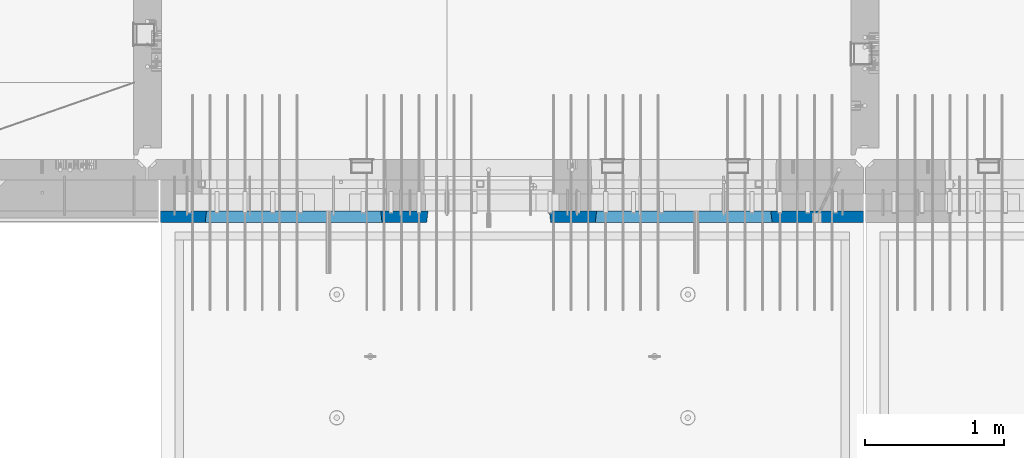
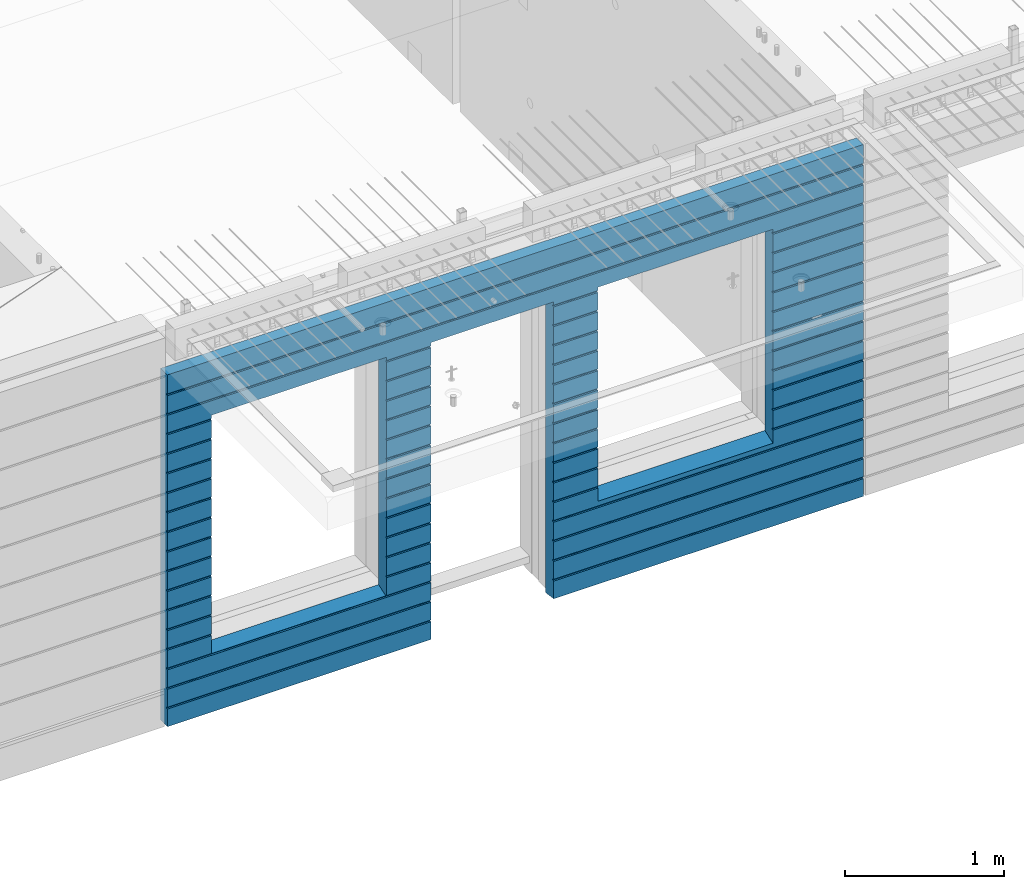
# One storey, part 231 of 350: 1 wall, 1 element without a shape of its own.
"""IFC2X3 building model written with IfcOpenShell, lengths in millimetres."""

from ifc_helpers import new_model, si_unit, frame, origin_with_axes, place, context, subcontext, project, spatial, faceted_brep, material, type_object, element, aggregate, save


model = new_model("IFC2X3")

# Units and contexts
model_context = context("Model", 3, precision=1e-05, world=origin_with_axes())
body_context = subcontext(model_context, "Body", "Model", "MODEL_VIEW")
ifc_project = project(units=[si_unit("LENGTHUNIT", "METRE", prefix="MILLI"), si_unit("AREAUNIT", "SQUARE_METRE"), si_unit("VOLUMEUNIT", "CUBIC_METRE"), si_unit("MASSUNIT", "GRAM", prefix="KILO"), si_unit("TIMEUNIT", "SECOND"), si_unit("PLANEANGLEUNIT", "RADIAN"), si_unit("SOLIDANGLEUNIT", "STERADIAN"), si_unit("THERMODYNAMICTEMPERATUREUNIT", "DEGREE_CELSIUS"), si_unit("LUMINOUSINTENSITYUNIT", "LUMEN")], contexts=[model_context])

# Site, building, storey
site_placement = place(None, origin_with_axes())
site = spatial("IfcSite", under=ifc_project, at=site_placement, CompositionType="ELEMENT")
building_placement = place(site_placement, origin_with_axes())
building = spatial("IfcBuilding", under=site, at=building_placement, CompositionType="ELEMENT")
storey_placement = place(building_placement, origin_with_axes())
storey = spatial("IfcBuildingStorey", under=building, at=storey_placement, Name="2", CompositionType="ELEMENT", Elevation=0.0)

# Assembly, wall
assembly_placement = place(storey_placement, origin_with_axes())
assembly = element("IfcElementAssembly", 1, at=assembly_placement, inside=storey, AssemblyPlace="NOTDEFINED", PredefinedType="REINFORCEMENT_UNIT")
ifc_material = material(Name="CONCRETE/C30/37")
wall_type = type_object("IfcWallType", PredefinedType="NOTDEFINED")
wall_placement = place(assembly_placement, frame((21810.0, 7587.5, 86102.5), z_axis=(0.0, 0.0, 1.0), x_axis=(-1.0, 3.00000001838171e-08, 0.0)))
wall = element("IfcWall", 2, at=wall_placement, type_object=wall_type, material=ifc_material, context=body_context, shape_type="Brep", body=[
    faceted_brep([(3465.15088791894, 41.2121213860573, -911.742424344746), (3464.99937278789, 42.5, -912.5), (3464.99937278789, 42.5, -912.000000055254), (4734.84785765683, 41.2121213860573, -911.742424344746), (4734.99937278789, 42.5, -912.5), (4734.99937278789, 42.5, -912.000000055254), (10.0, 42.5, -1347.5), (10.0, 42.5, -1212.00000005524), (2254.99845837354, 42.5, -1212.00000005524), (2254.99845837354, 42.5, -1347.5), (10.0, 32.4999992501662, -1210.00000000079), (2256.17512512844, 32.4999992501662, -1210.00000000079), (10.0000007500639, 32.499999249937, -1200.00000000079), (2256.17512514468, 32.4999991121731, -1199.99999959956), (10.0, 42.5, -1198.00000011075), (2254.99845837354, 42.5, -1198.00000011075), (10.0, 42.5, -1062.00000005522), (2254.99845837354, 42.5, -1062.00000005522), (10.0, 32.4999992506964, -1060.00000000079), (2256.17512512838, 32.4999992506964, -1060.00000000079), (10.0000007500657, 32.499999249937, -1050.00000000079), (2256.17512514461, 32.499999112697, -1049.99999959956), (10.0, 42.5, -1048.00000011074), (2254.99845837354, 42.5, -1048.00000011074), (10.0, 42.5, -912.000000055254), (2254.99845837354, 42.5, -912.000000055254), (10.0, 32.4999992512312, -910.000000000815), (2256.17512512832, 32.4999992512312, -910.000000000815), (10.0000007500657, 32.499999249937, -900.000000000786), (2256.17512514455, 32.4999991132318, -899.99999959959), (10.0, 42.5, -898.000000110769), (2254.99845837354, 42.5, -898.000000110769), (10.0, 42.5, -762.000000055225), (2254.99845837354, 42.5, -762.000000055225), (10.0, 32.4999992517696, -760.000000000771), (2256.17512512825, 32.4999992517696, -760.000000000771), (10.0000007500657, 32.499999249937, -750.000000000786), (2256.17512514449, 32.4999991137747, -749.999999599546), (10.0, 42.5, -748.00000011074), (2254.99845837354, 42.5, -748.00000011074), (675.00013572734, 42.5, 927.5), (1925.00013572734, 42.5, 927.5), (1935.00013572734, 42.5, 927.5), (1925.00013572734, -42.5, 932.5), (675.00013572734, -42.5, 932.5), (665.00013572734, 42.5, 927.5), (665.00013572734, 42.5, -712.5), (675.00013572734, -42.5, -662.5), (1925.00013572734, -42.5, -662.5), (1935.00013572734, 42.5, -712.5), (1925.00013572734, -42.5, 927.5), (1935.00013572734, 42.5, 901.999999889245), (1933.82366503463, 32.4999991119776, 900.000000400425), (1933.82366505087, 32.4999992499834, 889.9999999992), (1935.00013572734, 42.5, 887.999999944761), (1935.00013572734, 42.5, 751.999999889245), (1933.82366503463, 32.4999991119885, 750.000000400425), (1933.82366505087, 32.4999992499925, 739.9999999992), (1935.00013572734, 42.5, 737.999999944761), (1935.00013572734, 42.5, 601.99999988926), (1933.82366503463, 32.4999991120112, 600.00000040044), (1933.82366505087, 32.4999992500152, 589.999999999214), (1935.00013572734, 42.5, 587.999999944775), (1935.00013572734, 42.5, 451.999999889245), (1933.82366503464, 32.4999991120167, 450.000000400425), (1933.82366505087, 32.4999992500216, 439.9999999992), (1935.00013572734, 42.5, 437.999999944761), (1935.00013572734, 42.5, 301.999999889245), (1933.82366503464, 32.4999991120312, 300.000000400425), (1933.82366505087, 32.4999992500352, 289.9999999992), (1935.00013572734, 42.5, 287.999999944761), (1935.00013572734, 42.5, 151.999999889245), (1933.82366503464, 32.4999991120421, 150.000000400425), (1933.82366505088, 32.499999250047, 139.9999999992), (1935.00013572734, 42.5, 137.999999944761), (1935.00013572734, 42.5, 1.99999988923082), (1933.82366503515, 32.4999991164286, 4.00410499423742e-07), (1933.82366505139, 32.4999992544263, -10.0000000008149), (1935.00013572734, 42.5, -12.0000000552536), (1935.00013572734, 42.5, -148.000000110755), (1933.82366503509, 32.4999991158993, -149.99999959956), (1933.82366505132, 32.4999992538915, -160.000000000786), (1935.00013572734, 42.5, -162.000000055239), (1935.00013572734, 42.5, -298.000000110755), (1933.82366503503, 32.49999911536, -299.999999599575), (1933.82366505126, 32.4999992533594, -310.0000000008), (1935.00013572734, 42.5, -312.000000055239), (1935.00013572734, 42.5, -448.00000011074), (1933.82366503496, 32.4999991148343, -449.99999959956), (1933.8236650512, 32.4999992528337, -460.000000000786), (1935.00013572734, 42.5, -462.000000055225), (1935.00013572734, 42.5, -598.000000110755), (1933.8236650349, 32.499999114295, -599.999999599575), (1933.82366505114, 32.4999992522935, -610.0000000008), (1935.00013572734, 42.5, -612.000000055239), (2256.1751251447, 32.4999991119776, 900.000000400425), (2256.17512512846, 32.4999992499834, 889.9999999992), (2254.99845837354, 42.5, 887.999999944761), (2254.99845837354, 42.5, 751.999999889245), (2256.17512514469, 32.4999991119885, 750.000000400425), (2256.17512512846, 32.4999992499925, 739.9999999992), (2254.99845837354, 42.5, 737.999999944761), (2254.99845837354, 42.5, 601.99999988926), (2256.17512514469, 32.4999991120112, 600.00000040044), (2256.17512512846, 32.4999992500152, 589.999999999214), (2254.99845837354, 42.5, 587.999999944775), (2254.99845837354, 42.5, 451.999999889245), (2256.17512514469, 32.4999991120167, 450.000000400425), (2256.17512512846, 32.4999992500216, 439.9999999992), (2254.99845837354, 42.5, 437.999999944761), (2254.99845837354, 42.5, 301.999999889245), (2256.17512514469, 32.4999991120312, 300.000000400425), (2256.17512512846, 32.4999992500352, 289.9999999992), (2254.99845837354, 42.5, 287.999999944761), (2254.99845837354, 42.5, 151.999999889245), (2256.17512514469, 32.4999991120421, 150.000000400425), (2256.17512512846, 32.499999250047, 139.9999999992), (2254.99845837354, 42.5, 137.999999944761), (2254.99845837354, 42.5, 1.99999988923082), (2256.17512514417, 32.4999991164286, 4.00410499423742e-07), (2256.17512512794, 32.4999992544263, -10.0000000008149), (2254.99845837354, 42.5, -12.0000000552536), (2254.99845837354, 42.5, -148.000000110755), (2256.17512514424, 32.4999991158993, -149.99999959956), (2256.175125128, 32.4999992538915, -160.000000000786), (2254.99845837354, 42.5, -162.000000055239), (2254.99845837354, 42.5, -298.000000110755), (2256.1751251443, 32.49999911536, -299.999999599575), (2256.17512512806, 32.4999992533594, -310.0000000008), (2254.99845837354, 42.5, -312.000000055239), (2254.99845837354, 42.5, -448.00000011074), (2256.17512514436, 32.4999991148343, -449.99999959956), (2256.17512512813, 32.4999992528337, -460.000000000786), (2254.99845837354, 42.5, -462.000000055225), (2254.99845837354, 42.5, -598.000000110755), (2256.17512514443, 32.499999114295, -599.999999599575), (2256.17512512819, 32.4999992522935, -610.0000000008), (2254.99845837354, 42.5, -612.000000055239), (10.0, 42.5, -612.000000055239), (665.00013572734, 42.5, -612.000000055239), (10.0, 32.4999992522935, -610.0000000008), (666.176606403544, 32.4999992522935, -610.0000000008), (10.0000007500657, 32.499999249937, -600.000000000786), (666.176606419776, 32.499999114295, -599.999999599575), (10.0, 42.5, -598.000000110755), (665.00013572734, 42.5, -598.000000110755), (10.0, 42.5, -462.000000055225), (665.00013572734, 42.5, -462.000000055225), (10.0, 32.4999992528337, -460.000000000786), (666.176606403482, 32.4999992528337, -460.000000000786), (10.0000007500657, 32.499999249937, -450.000000000786), (666.176606419715, 32.4999991148343, -449.99999959956), (10.0, 42.5, -448.00000011074), (665.00013572734, 42.5, -448.00000011074), (10.0, 42.5, -312.000000055239), (665.00013572734, 42.5, -312.000000055239), (10.0, 32.4999992533594, -310.0000000008), (666.17660640342, 32.4999992533594, -310.0000000008), (10.0000007500657, 32.499999249937, -300.000000000786), (666.176606419653, 32.49999911536, -299.999999599575), (10.0, 42.5, -298.000000110755), (665.00013572734, 42.5, -298.000000110755), (10.0, 42.5, -162.000000055239), (665.00013572734, 42.5, -162.000000055239), (10.0, 32.4999992538915, -160.000000000786), (666.176606403355, 32.4999992538915, -160.000000000786), (10.0000007500657, 32.499999249937, -150.000000000786), (666.176606419591, 32.4999991158993, -149.99999959956), (10.0, 42.5, -148.000000110755), (665.00013572734, 42.5, -148.000000110755), (10.0, 42.5, -12.0000000552536), (665.00013572734, 42.5, -12.0000000552536), (10.0, 32.4999992544263, -10.0000000008149), (666.176606403293, 32.4999992544263, -10.0000000008149), (10.0000007500657, 32.499999249937, -7.8580342233181e-10), (666.176606419529, 32.4999991164286, 4.00410499423742e-07), (10.0, 42.5, 1.99999988923082), (665.00013572734, 42.5, 1.99999988923082), (10.0, 42.5, 137.999999944761), (665.00013572734, 42.5, 137.999999944761), (10.0, 32.499999250047, 139.9999999992), (666.176606403806, 32.499999250047, 139.9999999992), (10.0000007500657, 32.499999249937, 149.999999999214), (666.176606420046, 32.4999991120421, 150.000000400425), (10.0, 42.5, 151.999999889245), (665.00013572734, 42.5, 151.999999889245), (10.0, 42.5, 287.999999944761), (665.00013572734, 42.5, 287.999999944761), (10.0, 32.4999992500352, 289.9999999992), (666.176606403809, 32.4999992500352, 289.9999999992), (10.0000007500657, 32.499999249937, 299.999999999214), (666.176606420046, 32.4999991120312, 300.000000400425), (10.0, 42.5, 301.999999889245), (665.00013572734, 42.5, 301.999999889245), (10.0, 42.5, 437.999999944761), (665.00013572734, 42.5, 437.999999944761), (10.0, 32.4999992500216, 439.9999999992), (666.176606403809, 32.4999992500216, 439.9999999992), (10.0000007500657, 32.499999249937, 449.999999999214), (666.176606420046, 32.4999991120167, 450.000000400425), (10.0, 42.5, 451.999999889245), (665.00013572734, 42.5, 451.999999889245), (10.0, 42.5, 587.999999944775), (665.00013572734, 42.5, 587.999999944775), (10.0, 32.4999992500152, 589.999999999214), (666.176606403809, 32.4999992500152, 589.999999999214), (10.0000007500657, 32.499999249937, 599.999999999214), (666.176606420049, 32.4999991120112, 600.00000040044), (10.0, 42.5, 601.99999988926), (665.00013572734, 42.5, 601.99999988926), (10.0, 42.5, 737.999999944761), (665.00013572734, 42.5, 737.999999944761), (9.99999999999636, 32.4999992499925, 739.9999999992), (666.176606403813, 32.4999992499925, 739.9999999992), (10.0000007500657, 32.499999249937, 749.999999999214), (666.176606420049, 32.4999991119885, 750.000000400425), (10.0, 42.5, 751.999999889245), (665.00013572734, 42.5, 751.999999889245), (10.0, 42.5, 887.999999944761), (665.00013572734, 42.5, 887.999999944761), (10.0, 32.4999992499834, 889.9999999992), (666.176606403813, 32.4999992499834, 889.9999999992), (10.0000007500657, 32.499999249937, 899.999999999214), (666.176606420053, 32.4999991119776, 900.000000400425), (675.00013572734, -42.5, 927.5), (665.00013572734, 42.5, 901.999999889245), (10.0, 42.5, 901.999999889245), (10.0, 42.5, 1051.99999988925), (5055.0, 42.5, 1051.99999988925), (5055.0, 32.4999991119666, 1050.00000040043), (10.0000007500657, 32.499999249937, 1049.99999999921), (5055.0, 32.4999992499706, 1039.9999999992), (10.0, 32.4999992499706, 1039.9999999992), (5055.0, 42.5, 1037.99999994476), (10.0, 42.5, 1037.99999994476), (5055.0, 42.5, 901.999999889245), (5055.0, 32.4999991119776, 900.000000400425), (4733.82290209518, 32.4999991119776, 900.000000400425), (4734.99937278789, 42.5, 901.999999889245), (5055.0, 32.4999992499834, 889.9999999992), (4733.82290211141, 32.4999992499834, 889.9999999992), (5055.0, 42.5, 887.999999944761), (4734.99937278789, 42.5, 887.999999944761), (5055.0, 42.5, 751.999999889245), (4734.99937278789, 42.5, 751.999999889245), (5055.0, 32.4999991119885, 750.000000400425), (4733.82290209518, 32.4999991119885, 750.000000400425), (5055.0, 32.4999992499925, 739.9999999992), (4733.82290211142, 32.4999992499925, 739.9999999992), (5055.0, 42.5, 737.999999944761), (4734.99937278789, 42.5, 737.999999944761), (5055.0, 42.5, 601.99999988926), (4734.99937278789, 42.5, 601.99999988926), (5055.0, 32.4999991120112, 600.00000040044), (4733.82290209518, 32.4999991120112, 600.00000040044), (5055.0, 32.4999992500152, 589.999999999214), (4733.82290211142, 32.4999992500152, 589.999999999214), (5055.0, 42.5, 587.999999944775), (4734.99937278789, 42.5, 587.999999944775), (5055.0, 42.5, 451.999999889245), (4734.99937278789, 42.5, 451.999999889245), (5055.0, 32.4999991120167, 450.000000400425), (4733.82290209518, 32.4999991120167, 450.000000400425), (5055.0, 32.4999992500216, 439.9999999992), (4733.82290211142, 32.4999992500216, 439.9999999992), (5055.0, 42.5, 437.999999944761), (4734.99937278789, 42.5, 437.999999944761), (5055.0, 42.5, 301.999999889245), (4734.99937278789, 42.5, 301.999999889245), (5055.0, 32.4999991120312, 300.000000400425), (4733.82290209518, 32.4999991120312, 300.000000400425), (5055.0, 32.4999992500352, 289.9999999992), (4733.82290211142, 32.4999992500352, 289.9999999992), (5055.0, 42.5, 287.999999944761), (4734.99937278789, 42.5, 287.999999944761), (5055.0, 42.5, 151.999999889245), (4734.99937278789, 42.5, 151.999999889245), (5055.0, 32.4999991120421, 150.000000400425), (4733.82290209519, 32.4999991120421, 150.000000400425), (5055.0, 32.499999250047, 139.9999999992), (4733.82290211142, 32.499999250047, 139.9999999992), (5055.0, 42.5, 137.999999944761), (4734.99937278789, 42.5, 137.999999944761), (5055.0, 42.5, 1.99999988923082), (4734.99937278789, 42.5, 1.99999988923082), (5055.0, 32.4999991164286, 4.00410499423742e-07), (4733.8229020957, 32.4999991164286, 4.00410499423742e-07), (5055.0, 32.4999992544263, -10.0000000008149), (4733.82290211194, 32.4999992544263, -10.0000000008149), (5055.0, 42.5, -12.0000000552536), (4734.99937278789, 42.5, -12.0000000552536), (5055.0, 42.5, -148.000000110755), (4734.99937278789, 42.5, -148.000000110755), (5055.0, 32.4999991158993, -149.99999959956), (4733.82290209564, 32.4999991158993, -149.99999959956), (5055.0, 32.4999992538915, -160.000000000786), (4733.82290211188, 32.4999992538915, -160.000000000786), (5055.0, 42.5, -162.000000055239), (4734.99937278789, 42.5, -162.000000055239), (5055.0, 42.5, -298.000000110755), (4734.99937278789, 42.5, -298.000000110755), (5055.0, 32.49999911536, -299.999999599575), (4733.82290209558, 32.49999911536, -299.999999599575), (5055.0, 32.4999992533594, -310.0000000008), (4733.82290211181, 32.4999992533594, -310.0000000008), (5055.0, 42.5, -312.000000055239), (4734.99937278789, 42.5, -312.000000055239), (5055.0, 42.5, -448.00000011074), (4734.99937278789, 42.5, -448.00000011074), (5055.0, 32.4999991148343, -449.99999959956), (4733.82290209552, 32.4999991148343, -449.99999959956), (5055.0, 32.4999992528337, -460.000000000786), (4733.82290211175, 32.4999992528337, -460.000000000786), (5055.0, 42.5, -462.000000055225), (4734.99937278789, 42.5, -462.000000055225), (5055.0, 42.5, -598.000000110755), (4734.99937278789, 42.5, -598.000000110755), (5055.0, 32.499999114295, -599.999999599575), (4733.82290209545, 32.499999114295, -599.999999599575), (5055.0, 32.4999992522935, -610.0000000008), (4733.82290211169, 32.4999992522935, -610.0000000008), (5055.0, 42.5, -612.000000055239), (4734.99937278789, 42.5, -612.000000055239), (5055.0, 42.5, -748.00000011074), (4734.99937278789, 42.5, -748.00000011074), (5055.0, 32.4999991137747, -749.999999599546), (4733.82290209539, 32.4999991137747, -749.999999599546), (5055.0, 32.4999992517696, -760.000000000771), (4733.82290211162, 32.4999992517696, -760.000000000771), (5055.0, 42.5, -762.000000055225), (4734.99937278789, 42.5, -762.000000055225), (5055.0, 42.5, -898.000000110769), (4734.99937278789, 42.5, -898.000000110769), (5055.0, 32.4999991132318, -899.99999959959), (4733.82290209533, 32.4999991132318, -899.99999959959), (3466.1758434697, 32.499999204555, -906.617646590923), (3474.99937278789, -42.5, -862.5), (4724.99937278789, -42.5, -862.5), (4733.82290210607, 32.499999204555, -906.617646590923), (4724.99937278789, -42.5, 927.5), (4724.99937278789, -42.5, 932.5), (4734.99937278789, 42.5, 927.5), (2265.00051719707, 42.5, 927.5), (3135.00051719707, 42.5, 927.5), (3144.99845837354, 42.5, 927.5), (3134.99679170688, -42.5, 932.502857142856), (2265.00012504021, -42.5, 932.502857142856), (2254.99845837354, 42.5, 927.5), (4724.99937278789, 42.5, 927.5), (3474.99937278789, 42.5, 927.5), (3464.99937278789, 42.5, 927.5), (3464.99937278789, 42.5, 901.999999889245), (3144.99845837354, 42.5, 901.999999889245), (2254.99845837354, 42.5, 901.999999889245), (2265.00012504021, -42.5, 927.5), (2265.00012504021, -42.5, -1347.5), (10.0, -42.5, -1347.5), (10.0, 42.5, 1347.5), (10.0, -42.5, 1347.5), (5055.0, -42.5, 1347.5), (5055.0, 42.5, 1347.5), (5055.0, 42.5, 1201.99999988925), (10.0, 42.5, 1201.99999988925), (10.0, 42.5, 1187.99999994476), (10.0000007500657, 32.499999249937, 1199.99999999921), (9.99999999999636, 32.4999992499606, 1189.9999999992), (5055.0, 42.5, 1187.99999994476), (5055.0, 32.4999992499606, 1189.9999999992), (5055.0, 32.4999991119566, 1200.00000040043), (5055.0, -42.5, -1347.5), (5055.0, 42.5, -1347.5), (5055.0, 42.5, -1212.00000005524), (5055.0, 32.4999992501662, -1210.00000000079), (5055.0, 32.4999991121731, -1199.99999959956), (5055.0, 42.5, -1198.00000011075), (5055.0, 42.5, -1062.00000005522), (5055.0, 32.4999992506964, -1060.00000000079), (5055.0, 32.499999112697, -1049.99999959956), (5055.0, 42.5, -1048.00000011074), (5055.0, 42.5, -912.000000055254), (5055.0, 32.4999992512312, -910.000000000815), (3144.99845837354, 42.5, -1212.00000005524), (3143.82179161865, 32.4999992501662, -1210.00000000079), (3143.82179160241, 32.4999991121731, -1199.99999959956), (3144.99845837354, 42.5, -1198.00000011075), (3144.99845837354, 42.5, -1062.00000005522), (3143.82179161871, 32.4999992506964, -1060.00000000079), (3143.82179160247, 32.499999112697, -1049.99999959956), (3144.99845837354, 42.5, -1048.00000011074), (3144.99845837354, 42.5, -912.000000055254), (3143.82179161877, 32.4999992512312, -910.000000000815), (3466.17584348045, 32.4999991132318, -899.99999959959), (3143.82179160253, 32.4999991132318, -899.99999959959), (3464.99937278789, 42.5, -898.000000110769), (3144.99845837354, 42.5, -898.000000110769), (3464.99937278789, 42.5, -762.000000055225), (3144.99845837354, 42.5, -762.000000055225), (3466.17584346415, 32.4999992517696, -760.000000000771), (3143.82179161884, 32.4999992517696, -760.000000000771), (3466.17584348039, 32.4999991137747, -749.999999599546), (3143.8217916026, 32.4999991137747, -749.999999599546), (3464.99937278789, 42.5, -748.00000011074), (3144.99845837354, 42.5, -748.00000011074), (3464.99937278789, 42.5, -612.000000055239), (3144.99845837354, 42.5, -612.000000055239), (3466.17584346409, 32.4999992522935, -610.0000000008), (3143.8217916189, 32.4999992522935, -610.0000000008), (3466.17584348032, 32.499999114295, -599.999999599575), (3143.82179160266, 32.499999114295, -599.999999599575), (3464.99937278789, 42.5, -598.000000110755), (3144.99845837354, 42.5, -598.000000110755), (3464.99937278789, 42.5, -462.000000055225), (3144.99845837354, 42.5, -462.000000055225), (3466.17584346403, 32.4999992528337, -460.000000000786), (3143.82179161896, 32.4999992528337, -460.000000000786), (3466.17584348026, 32.4999991148343, -449.99999959956), (3143.82179160272, 32.4999991148343, -449.99999959956), (3464.99937278789, 42.5, -448.00000011074), (3144.99845837354, 42.5, -448.00000011074), (3464.99937278789, 42.5, -312.000000055239), (3144.99845837354, 42.5, -312.000000055239), (3466.17584346396, 32.4999992533594, -310.0000000008), (3143.82179161902, 32.4999992533594, -310.0000000008), (3466.1758434802, 32.49999911536, -299.999999599575), (3143.82179160278, 32.49999911536, -299.999999599575), (3464.99937278789, 42.5, -298.000000110755), (3144.99845837354, 42.5, -298.000000110755), (3464.99937278789, 42.5, -162.000000055239), (3144.99845837354, 42.5, -162.000000055239), (3466.1758434639, 32.4999992538915, -160.000000000786), (3143.82179161909, 32.4999992538915, -160.000000000786), (3466.17584348014, 32.4999991158993, -149.99999959956), (3143.82179160284, 32.4999991158993, -149.99999959956), (3464.99937278789, 42.5, -148.000000110755), (3144.99845837354, 42.5, -148.000000110755), (3464.99937278789, 42.5, -12.0000000552536), (3144.99845837354, 42.5, -12.0000000552536), (3466.17584346384, 32.4999992544263, -10.0000000008149), (3143.82179161915, 32.4999992544263, -10.0000000008149), (3466.17584348008, 32.4999991164286, 4.00410499423742e-07), (3143.82179160291, 32.4999991164286, 4.00410499423742e-07), (3464.99937278789, 42.5, 1.99999988923082), (3144.99845837354, 42.5, 1.99999988923082), (3464.99937278789, 42.5, 137.999999944761), (3144.99845837354, 42.5, 137.999999944761), (3466.17584346435, 32.499999250047, 139.9999999992), (3143.82179161863, 32.499999250047, 139.9999999992), (3466.17584348059, 32.4999991120421, 150.000000400425), (3143.82179160239, 32.4999991120421, 150.000000400425), (3464.99937278789, 42.5, 151.999999889245), (3144.99845837354, 42.5, 151.999999889245), (3464.99937278789, 42.5, 287.999999944761), (3144.99845837354, 42.5, 287.999999944761), (3466.17584346436, 32.4999992500352, 289.9999999992), (3143.82179161863, 32.4999992500352, 289.9999999992), (3466.17584348059, 32.4999991120312, 300.000000400425), (3143.82179160239, 32.4999991120312, 300.000000400425), (3464.99937278789, 42.5, 301.999999889245), (3144.99845837354, 42.5, 301.999999889245), (3464.99937278789, 42.5, 437.999999944761), (3144.99845837354, 42.5, 437.999999944761), (3466.17584346436, 32.4999992500216, 439.9999999992), (3143.82179161863, 32.4999992500216, 439.9999999992), (3466.17584348059, 32.4999991120167, 450.000000400425), (3143.82179160239, 32.4999991120167, 450.000000400425), (3464.99937278789, 42.5, 451.999999889245), (3144.99845837354, 42.5, 451.999999889245), (3464.99937278789, 42.5, 587.999999944775), (3144.99845837354, 42.5, 587.999999944775), (3466.17584346436, 32.4999992500152, 589.999999999214), (3143.82179161863, 32.4999992500152, 589.999999999214), (3466.1758434806, 32.4999991120112, 600.00000040044), (3143.82179160239, 32.4999991120112, 600.00000040044), (3464.99937278789, 42.5, 601.99999988926), (3144.99845837354, 42.5, 601.99999988926), (3464.99937278789, 42.5, 737.999999944761), (3144.99845837354, 42.5, 737.999999944761), (3466.17584346436, 32.4999992499925, 739.9999999992), (3143.82179161863, 32.4999992499925, 739.9999999992), (3466.1758434806, 32.4999991119885, 750.000000400425), (3143.82179160239, 32.4999991119885, 750.000000400425), (3464.99937278789, 42.5, 751.999999889245), (3144.99845837354, 42.5, 751.999999889245), (3464.99937278789, 42.5, 887.999999944761), (3144.99845837354, 42.5, 887.999999944761), (3466.17584346436, 32.4999992499834, 889.9999999992), (3143.82179161863, 32.4999992499834, 889.9999999992), (3466.1758434806, 32.4999991119776, 900.000000400425), (3143.82179160239, 32.4999991119776, 900.000000400425), (3474.99937278789, -42.5, 932.5), (3474.99937278789, -42.5, 927.5), (3134.99679170688, -42.5, 927.5), (3134.99679170688, -42.5, -1347.5), (3144.99845837354, 42.5, -1347.5)], [[[0, 1, 2]], [[3, 4, 1, 0]], [[5, 4, 3]], [[6, 7, 8, 9]], [[7, 10, 11, 8]], [[10, 12, 13, 11]], [[12, 14, 15, 13]], [[14, 16, 17, 15]], [[16, 18, 19, 17]], [[18, 20, 21, 19]], [[20, 22, 23, 21]], [[22, 24, 25, 23]], [[24, 26, 27, 25]], [[26, 28, 29, 27]], [[28, 30, 31, 29]], [[30, 32, 33, 31]], [[32, 34, 35, 33]], [[34, 36, 37, 35]], [[36, 38, 39, 37]], [[40, 41, 42, 43, 44, 45]], [[46, 47, 48, 49]], [[50, 43, 42, 51, 52, 53, 54, 55, 56, 57, 58, 59, 60, 61, 62, 63, 64, 65, 66, 67, 68, 69, 70, 71, 72, 73, 74, 75, 76, 77, 78, 79, 80, 81, 82, 83, 84, 85, 86, 87, 88, 89, 90, 91, 92, 93, 94, 49, 48]], [[53, 52, 95, 96]], [[54, 53, 96, 97]], [[55, 54, 97, 98]], [[56, 55, 98, 99]], [[57, 56, 99, 100]], [[58, 57, 100, 101]], [[59, 58, 101, 102]], [[60, 59, 102, 103]], [[61, 60, 103, 104]], [[62, 61, 104, 105]], [[63, 62, 105, 106]], [[64, 63, 106, 107]], [[65, 64, 107, 108]], [[66, 65, 108, 109]], [[67, 66, 109, 110]], [[68, 67, 110, 111]], [[69, 68, 111, 112]], [[70, 69, 112, 113]], [[71, 70, 113, 114]], [[72, 71, 114, 115]], [[73, 72, 115, 116]], [[74, 73, 116, 117]], [[75, 74, 117, 118]], [[76, 75, 118, 119]], [[77, 76, 119, 120]], [[78, 77, 120, 121]], [[79, 78, 121, 122]], [[80, 79, 122, 123]], [[81, 80, 123, 124]], [[82, 81, 124, 125]], [[83, 82, 125, 126]], [[84, 83, 126, 127]], [[85, 84, 127, 128]], [[86, 85, 128, 129]], [[87, 86, 129, 130]], [[88, 87, 130, 131]], [[89, 88, 131, 132]], [[90, 89, 132, 133]], [[91, 90, 133, 134]], [[92, 91, 134, 135]], [[93, 92, 135, 136]], [[94, 93, 136, 137]], [[38, 138, 139, 46, 49, 94, 137, 39]], [[138, 140, 141, 139]], [[140, 142, 143, 141]], [[142, 144, 145, 143]], [[144, 146, 147, 145]], [[146, 148, 149, 147]], [[148, 150, 151, 149]], [[150, 152, 153, 151]], [[152, 154, 155, 153]], [[154, 156, 157, 155]], [[156, 158, 159, 157]], [[158, 160, 161, 159]], [[160, 162, 163, 161]], [[162, 164, 165, 163]], [[164, 166, 167, 165]], [[166, 168, 169, 167]], [[168, 170, 171, 169]], [[170, 172, 173, 171]], [[172, 174, 175, 173]], [[174, 176, 177, 175]], [[176, 178, 179, 177]], [[178, 180, 181, 179]], [[180, 182, 183, 181]], [[182, 184, 185, 183]], [[184, 186, 187, 185]], [[186, 188, 189, 187]], [[188, 190, 191, 189]], [[190, 192, 193, 191]], [[192, 194, 195, 193]], [[194, 196, 197, 195]], [[196, 198, 199, 197]], [[198, 200, 201, 199]], [[200, 202, 203, 201]], [[202, 204, 205, 203]], [[204, 206, 207, 205]], [[206, 208, 209, 207]], [[208, 210, 211, 209]], [[210, 212, 213, 211]], [[212, 214, 215, 213]], [[214, 216, 217, 215]], [[216, 218, 219, 217]], [[218, 220, 221, 219]], [[220, 222, 223, 221]], [[45, 44, 224, 47, 46, 139, 141, 143, 145, 147, 149, 151, 153, 155, 157, 159, 161, 163, 165, 167, 169, 171, 173, 175, 177, 179, 181, 183, 185, 187, 189, 191, 193, 195, 197, 199, 201, 203, 205, 207, 209, 211, 213, 215, 217, 219, 221, 223, 225]], [[222, 226, 225, 223]], [[227, 228, 229, 230]], [[230, 229, 231, 232]], [[232, 231, 233, 234]], [[235, 236, 237, 238]], [[236, 239, 240, 237]], [[239, 241, 242, 240]], [[241, 243, 244, 242]], [[243, 245, 246, 244]], [[245, 247, 248, 246]], [[247, 249, 250, 248]], [[249, 251, 252, 250]], [[251, 253, 254, 252]], [[253, 255, 256, 254]], [[255, 257, 258, 256]], [[257, 259, 260, 258]], [[259, 261, 262, 260]], [[261, 263, 264, 262]], [[263, 265, 266, 264]], [[265, 267, 268, 266]], [[267, 269, 270, 268]], [[269, 271, 272, 270]], [[271, 273, 274, 272]], [[273, 275, 276, 274]], [[275, 277, 278, 276]], [[277, 279, 280, 278]], [[279, 281, 282, 280]], [[281, 283, 284, 282]], [[283, 285, 286, 284]], [[285, 287, 288, 286]], [[287, 289, 290, 288]], [[289, 291, 292, 290]], [[291, 293, 294, 292]], [[293, 295, 296, 294]], [[295, 297, 298, 296]], [[297, 299, 300, 298]], [[299, 301, 302, 300]], [[301, 303, 304, 302]], [[303, 305, 306, 304]], [[305, 307, 308, 306]], [[307, 309, 310, 308]], [[309, 311, 312, 310]], [[311, 313, 314, 312]], [[313, 315, 316, 314]], [[315, 317, 318, 316]], [[317, 319, 320, 318]], [[319, 321, 322, 320]], [[321, 323, 324, 322]], [[323, 325, 326, 324]], [[325, 327, 328, 326]], [[327, 329, 330, 328]], [[329, 331, 332, 330]], [[331, 333, 334, 332]], [[335, 336, 337, 338]], [[339, 340, 341, 238, 237, 240, 242, 244, 246, 248, 250, 252, 254, 256, 258, 260, 262, 264, 266, 268, 270, 272, 274, 276, 278, 280, 282, 284, 286, 288, 290, 292, 294, 296, 298, 300, 302, 304, 306, 308, 310, 312, 314, 316, 318, 320, 322, 324, 326, 328, 330, 332, 334, 338, 337]], [[342, 343, 344, 345, 346, 347]], [[51, 42, 41, 40, 45, 225, 226, 234, 233, 235, 238, 341, 348, 349, 350, 351, 352, 344, 343, 342, 347, 353]], [[52, 51, 353, 95]], [[347, 346, 354, 355, 9, 8, 11, 13, 15, 17, 19, 21, 23, 25, 27, 29, 31, 33, 35, 37, 39, 137, 136, 135, 134, 133, 132, 131, 130, 129, 128, 127, 126, 125, 124, 123, 122, 121, 120, 119, 118, 117, 116, 115, 114, 113, 112, 111, 110, 109, 108, 107, 106, 105, 104, 103, 102, 101, 100, 99, 98, 97, 96, 95, 353]], [[356, 6, 9, 355]], [[357, 358, 359, 360]], [[357, 360, 361, 362]], [[363, 227, 230, 232, 234, 226, 222, 220, 218, 216, 214, 212, 210, 208, 206, 204, 202, 200, 198, 196, 194, 192, 190, 188, 186, 184, 182, 180, 178, 176, 174, 172, 170, 168, 166, 164, 162, 160, 158, 156, 154, 152, 150, 148, 146, 144, 142, 140, 138, 38, 36, 34, 32, 30, 28, 26, 24, 22, 20, 18, 16, 14, 12, 10, 7, 6, 356, 358, 357, 362, 364, 365]], [[228, 227, 363, 366]], [[365, 367, 366, 363]], [[364, 368, 367, 365]], [[362, 361, 368, 364]], [[360, 359, 369, 370, 371, 372, 373, 374, 375, 376, 377, 378, 379, 380, 333, 331, 329, 327, 325, 323, 321, 319, 317, 315, 313, 311, 309, 307, 305, 303, 301, 299, 297, 295, 293, 291, 289, 287, 285, 283, 281, 279, 277, 275, 273, 271, 269, 267, 265, 263, 261, 259, 257, 255, 253, 251, 249, 247, 245, 243, 241, 239, 236, 235, 233, 231, 229, 228, 366, 367, 368, 361]], [[372, 371, 381, 382]], [[373, 372, 382, 383]], [[374, 373, 383, 384]], [[375, 374, 384, 385]], [[376, 375, 385, 386]], [[377, 376, 386, 387]], [[378, 377, 387, 388]], [[2, 1, 4, 5, 379, 378, 388, 389]], [[380, 379, 5, 3, 0, 2, 389, 390]], [[391, 335, 338, 334, 333, 380, 390, 392]], [[393, 391, 392, 394]], [[395, 393, 394, 396]], [[397, 395, 396, 398]], [[399, 397, 398, 400]], [[401, 399, 400, 402]], [[403, 401, 402, 404]], [[405, 403, 404, 406]], [[407, 405, 406, 408]], [[409, 407, 408, 410]], [[411, 409, 410, 412]], [[413, 411, 412, 414]], [[415, 413, 414, 416]], [[417, 415, 416, 418]], [[419, 417, 418, 420]], [[421, 419, 420, 422]], [[423, 421, 422, 424]], [[425, 423, 424, 426]], [[427, 425, 426, 428]], [[429, 427, 428, 430]], [[431, 429, 430, 432]], [[433, 431, 432, 434]], [[435, 433, 434, 436]], [[437, 435, 436, 438]], [[439, 437, 438, 440]], [[441, 439, 440, 442]], [[443, 441, 442, 444]], [[445, 443, 444, 446]], [[447, 445, 446, 448]], [[449, 447, 448, 450]], [[451, 449, 450, 452]], [[453, 451, 452, 454]], [[455, 453, 454, 456]], [[457, 455, 456, 458]], [[459, 457, 458, 460]], [[461, 459, 460, 462]], [[463, 461, 462, 464]], [[465, 463, 464, 466]], [[467, 465, 466, 468]], [[469, 467, 468, 470]], [[471, 469, 470, 472]], [[473, 471, 472, 474]], [[475, 473, 474, 476]], [[477, 475, 476, 478]], [[479, 477, 478, 480]], [[481, 479, 480, 482]], [[483, 481, 482, 484]], [[485, 483, 484, 486]], [[487, 485, 486, 488]], [[351, 487, 488, 352]], [[350, 489, 490, 336, 335, 391, 393, 395, 397, 399, 401, 403, 405, 407, 409, 411, 413, 415, 417, 419, 421, 423, 425, 427, 429, 431, 433, 435, 437, 439, 441, 443, 445, 447, 449, 451, 453, 455, 457, 459, 461, 463, 465, 467, 469, 471, 473, 475, 477, 479, 481, 483, 485, 487, 351]], [[349, 348, 341, 340, 489, 350]], [[491, 492, 369, 359, 358, 356, 355, 354, 346, 345], [339, 337, 336, 490, 489, 340], [50, 48, 47, 224, 44, 43]], [[370, 369, 492, 493]], [[491, 345, 344, 352, 488, 486, 484, 482, 480, 478, 476, 474, 472, 470, 468, 466, 464, 462, 460, 458, 456, 454, 452, 450, 448, 446, 444, 442, 440, 438, 436, 434, 432, 430, 428, 426, 424, 422, 420, 418, 416, 414, 412, 410, 408, 406, 404, 402, 400, 398, 396, 394, 392, 390, 389, 388, 387, 386, 385, 384, 383, 382, 381, 493, 492]], [[371, 370, 493, 381]]]),
])
aggregate(assembly, [wall])

save(model, "model.ifc")
